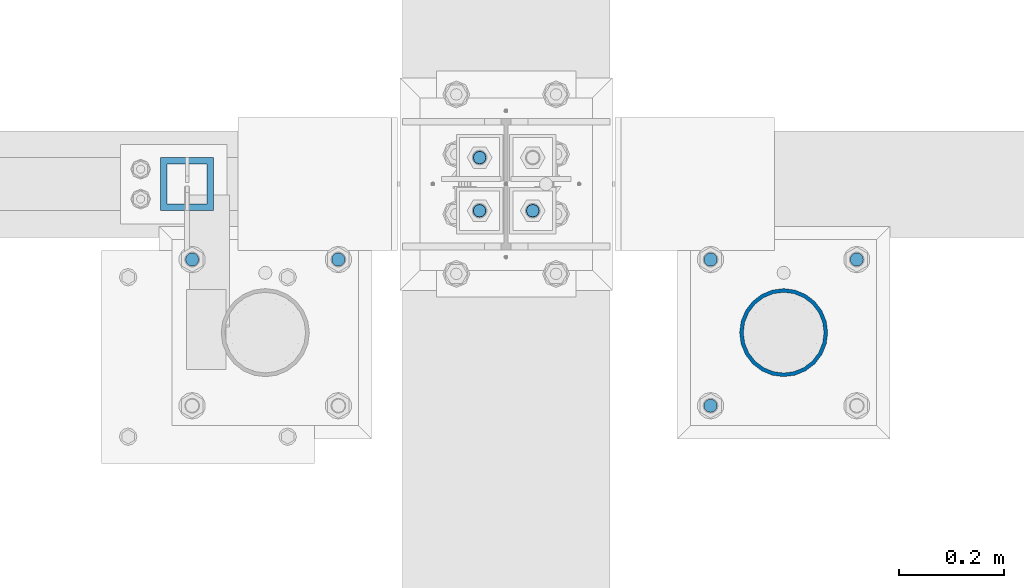
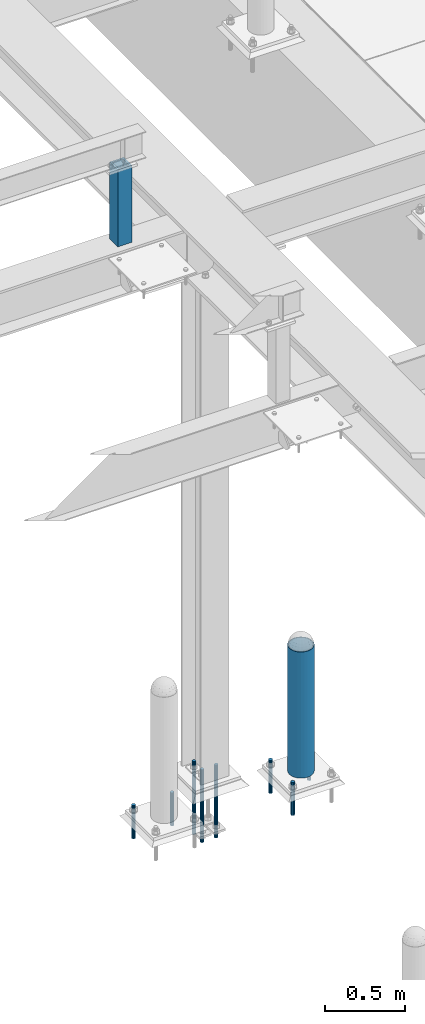
# One storey, part 1445 of 3843: 10 columns, 5 elements without a shape of their own.
"""IFC2X3 building model written with IfcOpenShell, lengths in millimetres."""

from ifc_helpers import new_model, si_unit, frame, origin_with_axes, place, context, subcontext, project, spatial, faceted_brep, material, type_object, element, aggregate, save


model = new_model("IFC2X3")

# Units and contexts
model_context = context("Model", 3, precision=1e-05, world=origin_with_axes())
body_context = subcontext(model_context, "Body", "Model", "MODEL_VIEW")
ifc_project = project(units=[si_unit("LENGTHUNIT", "METRE", prefix="MILLI"), si_unit("AREAUNIT", "SQUARE_METRE"), si_unit("VOLUMEUNIT", "CUBIC_METRE"), si_unit("MASSUNIT", "GRAM", prefix="KILO"), si_unit("TIMEUNIT", "SECOND"), si_unit("PLANEANGLEUNIT", "RADIAN"), si_unit("SOLIDANGLEUNIT", "STERADIAN"), si_unit("THERMODYNAMICTEMPERATUREUNIT", "DEGREE_CELSIUS"), si_unit("LUMINOUSINTENSITYUNIT", "LUMEN")], contexts=[model_context])

# Site, building, storey
site_placement = place(None, origin_with_axes())
site = spatial("IfcSite", under=ifc_project, at=site_placement, CompositionType="ELEMENT")
building_placement = place(site_placement, origin_with_axes())
building = spatial("IfcBuilding", under=site, at=building_placement, Name="Undefined", CompositionType="ELEMENT")
storey_placement = place(building_placement, origin_with_axes())
storey = spatial("IfcBuildingStorey", under=building, at=storey_placement, Name="Undefined", CompositionType="ELEMENT", Elevation=0.0)

# Assembly, column
assembly_1_placement = place(storey_placement, origin_with_axes())
assembly_1 = element("IfcElementAssembly", 1, at=assembly_1_placement, inside=storey, Name="PIPE_BOLLARD", AssemblyPlace="NOTDEFINED", PredefinedType="RIGID_FRAME")
ifc_material_1 = material()
column_type_1 = type_object("IfcColumnType", Name="PIPE6SCH40", PredefinedType="NOTDEFINED")
column_1_placement = place(assembly_1_placement, frame((37106.2721557617, 14714.9457781578, 30480.0), z_axis=(-1.0, 0.0, 0.0), x_axis=(0.0, 0.0, 1.0)))
column_1 = element("IfcColumn", 2, at=column_1_placement, type_object=column_type_1, material=ifc_material_1, Name="PIPE_BOLLARD", ObjectType="PIPE6SCH40", context=body_context, shape_type="Brep", body=[
    faceted_brep([(50.7999999999993, -77.0890000000072, 0.0), (50.7999999999993, -74.4622560228017, 19.9521013679114), (1016.0, -74.4622560228017, 19.9521013679114), (1016.0, -77.0890000000072, 0.0), (50.7999999999993, -66.7610323523404, 38.5445000000036), (1016.0, -66.7610323523404, 38.5445000000036), (50.7999999999993, -54.5101546548831, 54.5101546548904), (1016.0, -54.5101546548831, 54.5101546548904), (50.7999999999993, -38.5445000000036, 66.7610323523404), (1016.0, -38.5445000000036, 66.7610323523404), (50.7999999999993, -19.9521013679041, 74.4622560227945), (1016.0, -19.9521013679041, 74.4622560227945), (50.7999999999993, 0.0, 77.0889999999999), (1016.0, 0.0, 77.0889999999999), (50.7999999999993, 19.9521013679041, 74.4622560227945), (1016.0, 19.9521013679041, 74.4622560227945), (50.7999999999993, 38.5445000000036, 66.7610323523404), (1016.0, 38.5445000000036, 66.7610323523404), (50.7999999999993, 54.5101546548831, 54.5101546548904), (1016.0, 54.5101546548831, 54.5101546548904), (50.7999999999993, 66.7610323523404, 38.5445000000036), (1016.0, 66.7610323523404, 38.5445000000036), (50.7999999999993, 74.4622560228017, 19.9521013679114), (1016.0, 74.4622560228017, 19.9521013679114), (50.7999999999993, 77.0890000000072, 0.0), (1016.0, 77.0890000000072, 0.0), (50.7999999999993, 74.4622560228017, -19.9521013679114), (1016.0, 74.4622560228017, -19.9521013679114), (50.7999999999993, 66.7610323523404, -38.5445000000036), (1016.0, 66.7610323523404, -38.5445000000036), (50.7999999999993, 54.5101546548831, -54.5101546548904), (1016.0, 54.5101546548831, -54.5101546548904), (50.7999999999993, 38.5445000000036, -66.7610323523404), (1016.0, 38.5445000000036, -66.7610323523404), (50.7999999999993, 19.9521013679041, -74.4622560227945), (1016.0, 19.9521013679041, -74.4622560227945), (50.7999999999993, 0.0, -77.0889999999999), (1016.0, 0.0, -77.0889999999999), (50.7999999999993, -19.9521013679041, -74.4622560227945), (1016.0, -19.9521013679041, -74.4622560227945), (50.7999999999993, -38.5445000000036, -66.7610323523404), (1016.0, -38.5445000000036, -66.7610323523404), (50.7999999999993, -54.5101546548831, -54.5101546548904), (1016.0, -54.5101546548831, -54.5101546548904), (50.7999999999993, -66.7610323523404, -38.5445000000036), (1016.0, -66.7610323523404, -38.5445000000036), (50.7999999999993, -74.4622560228017, -19.9521013679114), (1016.0, -74.4622560228017, -19.9521013679114), (50.7999999999993, -84.2010000000009, 0.0), (50.7999999999993, -81.3319204993604, -21.7928224166753), (1016.0, -81.3319204993604, -21.7928224166753), (1016.0, -84.2010000000009, 0.0), (50.7999999999993, -72.9202050240565, -42.1005000000005), (1016.0, -72.9202050240565, -42.1005000000005), (50.7999999999993, -59.5390980826924, -59.5390980826851), (1016.0, -59.5390980826924, -59.5390980826851), (50.7999999999993, -42.1005000000005, -72.9202050240565), (1016.0, -42.1005000000005, -72.9202050240565), (50.7999999999993, -21.7928224166826, -81.3319204993677), (1016.0, -21.7928224166826, -81.3319204993677), (50.7999999999993, 0.0, -84.2010000000009), (1016.0, 0.0, -84.2010000000009), (50.7999999999993, 21.7928224166826, -81.3319204993677), (1016.0, 21.7928224166826, -81.3319204993677), (50.7999999999993, 42.1005000000005, -72.9202050240565), (1016.0, 42.1005000000005, -72.9202050240565), (50.7999999999993, 59.5390980826924, -59.5390980826851), (1016.0, 59.5390980826924, -59.5390980826851), (50.7999999999993, 72.9202050240565, -42.1005000000005), (1016.0, 72.9202050240565, -42.1005000000005), (50.7999999999993, 81.3319204993604, -21.7928224166753), (1016.0, 81.3319204993604, -21.7928224166753), (50.7999999999993, 84.2010000000009, 0.0), (1016.0, 84.2010000000009, 0.0), (50.7999999999993, 81.3319204993604, 21.7928224166753), (1016.0, 81.3319204993604, 21.7928224166753), (50.7999999999993, 72.9202050240565, 42.1005000000005), (1016.0, 72.9202050240565, 42.1005000000005), (50.7999999999993, 59.5390980826924, 59.5390980826851), (1016.0, 59.5390980826924, 59.5390980826851), (50.7999999999993, 42.1005000000005, 72.9202050240565), (1016.0, 42.1005000000005, 72.9202050240565), (50.7999999999993, 21.7928224166826, 81.3319204993677), (1016.0, 21.7928224166826, 81.3319204993677), (50.7999999999993, 0.0, 84.2010000000009), (1016.0, 0.0, 84.2010000000009), (50.7999999999993, -21.7928224166826, 81.3319204993677), (1016.0, -21.7928224166826, 81.3319204993677), (50.7999999999993, -42.1005000000005, 72.9202050240565), (1016.0, -42.1005000000005, 72.9202050240565), (50.7999999999993, -59.5390980826924, 59.5390980826851), (1016.0, -59.5390980826924, 59.5390980826851), (50.7999999999993, -72.9202050240565, 42.1005000000005), (1016.0, -72.9202050240565, 42.1005000000005), (50.7999999999993, -81.3319204993604, 21.7928224166753), (1016.0, -81.3319204993604, 21.7928224166753)], [[[0, 1, 2, 3]], [[1, 4, 5, 2]], [[4, 6, 7, 5]], [[6, 8, 9, 7]], [[8, 10, 11, 9]], [[10, 12, 13, 11]], [[12, 14, 15, 13]], [[14, 16, 17, 15]], [[16, 18, 19, 17]], [[18, 20, 21, 19]], [[20, 22, 23, 21]], [[22, 24, 25, 23]], [[24, 26, 27, 25]], [[26, 28, 29, 27]], [[28, 30, 31, 29]], [[30, 32, 33, 31]], [[32, 34, 35, 33]], [[34, 36, 37, 35]], [[36, 38, 39, 37]], [[38, 40, 41, 39]], [[40, 42, 43, 41]], [[42, 44, 45, 43]], [[44, 46, 47, 45]], [[46, 0, 3, 47]], [[48, 49, 50, 51]], [[49, 52, 53, 50]], [[52, 54, 55, 53]], [[54, 56, 57, 55]], [[56, 58, 59, 57]], [[58, 60, 61, 59]], [[60, 62, 63, 61]], [[62, 64, 65, 63]], [[64, 66, 67, 65]], [[66, 68, 69, 67]], [[68, 70, 71, 69]], [[70, 72, 73, 71]], [[72, 74, 75, 73]], [[74, 76, 77, 75]], [[76, 78, 79, 77]], [[78, 80, 81, 79]], [[80, 82, 83, 81]], [[82, 84, 85, 83]], [[84, 86, 87, 85]], [[86, 88, 89, 87]], [[88, 90, 91, 89]], [[90, 92, 93, 91]], [[92, 94, 95, 93]], [[94, 48, 51, 95]], [[53, 55, 57, 59, 61, 63, 65, 67, 69, 71, 73, 75, 77, 79, 81, 83, 85, 87, 89, 91, 93, 95, 51, 50], [5, 7, 9, 11, 13, 15, 17, 19, 21, 23, 25, 27, 29, 31, 33, 35, 37, 39, 41, 43, 45, 47, 3, 2]], [[94, 92, 90, 88, 86, 84, 82, 80, 78, 76, 74, 72, 70, 68, 66, 64, 62, 60, 58, 56, 54, 52, 49, 48], [46, 44, 42, 40, 38, 36, 34, 32, 30, 28, 26, 24, 22, 20, 18, 16, 14, 12, 10, 8, 6, 4, 1, 0]]]),
])
aggregate(assembly_1, [column_1])

# Assembly, columns
assembly_2_placement = place(storey_placement, origin_with_axes())
assembly_2 = element("IfcElementAssembly", 3, at=assembly_2_placement, inside=storey, Name="TEMPLATE", AssemblyPlace="NOTDEFINED", PredefinedType="RIGID_FRAME")
ifc_material_2 = material(Name="STEEL/316 SS")
column_type_2 = type_object("IfcColumnType", PredefinedType="NOTDEFINED")
column_2_placement = place(assembly_2_placement, frame((36255.3715698242, 14854.6457781578, 30581.6), z_axis=(-1.0, 0.0, 0.0), x_axis=(0.0, 0.0, -1.0)))
column_2 = element("IfcColumn", 4, at=column_2_placement, type_object=column_type_2, material=ifc_material_2, Name="ANCHOR_ROD", context=body_context, shape_type="Brep", body=[
    faceted_brep([(0.0, -12.6999999999971, 0.0), (0.0, -10.9985226280696, -6.34999999999854), (253.999, -10.9985226280696, -6.34999999999854), (253.999, -12.6999999999971, 0.0), (0.0, -6.35000000000582, -10.9985226280623), (253.999, -6.35000000000582, -10.9985226280623), (0.0, 0.0, -12.6999999999971), (253.999, 0.0, -12.6999999999971), (0.0, 6.35000000000582, -10.9985226280623), (253.999, 6.35000000000582, -10.9985226280623), (0.0, 10.9985226280696, -6.34999999999854), (253.999, 10.9985226280696, -6.34999999999854), (0.0, 12.6999999999971, 0.0), (253.999, 12.6999999999971, 0.0), (0.0, 10.9985226280696, 6.34999999999854), (253.999, 10.9985226280696, 6.34999999999854), (0.0, 6.35000000000582, 10.9985226280623), (253.999, 6.35000000000582, 10.9985226280623), (0.0, 0.0, 12.6999999999971), (253.999, 0.0, 12.6999999999971), (0.0, -6.35000000000582, 10.9985226280623), (253.999, -6.35000000000582, 10.9985226280623), (0.0, -10.9985226280696, 6.34999999999854), (253.999, -10.9985226280696, 6.34999999999854)], [[[0, 1, 2, 3]], [[1, 4, 5, 2]], [[4, 6, 7, 5]], [[6, 8, 9, 7]], [[8, 10, 11, 9]], [[10, 12, 13, 11]], [[12, 14, 15, 13]], [[14, 16, 17, 15]], [[16, 18, 19, 17]], [[18, 20, 21, 19]], [[20, 22, 23, 21]], [[22, 0, 3, 23]], [[5, 7, 9, 11, 13, 15, 17, 19, 21, 23, 3, 2]], [[22, 20, 18, 16, 14, 12, 10, 8, 6, 4, 1, 0]]]),
])
column_3_placement = place(assembly_2_placement, frame((35975.9715698242, 14854.6457781578, 30581.6), z_axis=(-1.0, 0.0, 0.0), x_axis=(0.0, 0.0, -1.0)))
column_3 = element("IfcColumn", 5, at=column_3_placement, type_object=column_type_2, material=ifc_material_2, Name="ANCHOR_ROD", context=body_context, shape_type="Brep", body=[
    faceted_brep([(0.0, -12.6999999999971, 0.0), (0.0, -10.9985226280696, -6.34999999999854), (253.999, -10.9985226280696, -6.34999999999854), (253.999, -12.6999999999971, 0.0), (0.0, -6.35000000000582, -10.9985226280623), (253.999, -6.35000000000582, -10.9985226280623), (0.0, 0.0, -12.6999999999971), (253.999, 0.0, -12.6999999999971), (0.0, 6.35000000000582, -10.9985226280623), (253.999, 6.35000000000582, -10.9985226280623), (0.0, 10.9985226280696, -6.34999999999854), (253.999, 10.9985226280696, -6.34999999999854), (0.0, 12.6999999999971, 0.0), (253.999, 12.6999999999971, 0.0), (0.0, 10.9985226280696, 6.34999999999854), (253.999, 10.9985226280696, 6.34999999999854), (0.0, 6.35000000000582, 10.9985226280623), (253.999, 6.35000000000582, 10.9985226280623), (0.0, 0.0, 12.6999999999971), (253.999, 0.0, 12.6999999999971), (0.0, -6.35000000000582, 10.9985226280623), (253.999, -6.35000000000582, 10.9985226280623), (0.0, -10.9985226280696, 6.34999999999854), (253.999, -10.9985226280696, 6.34999999999854)], [[[0, 1, 2, 3]], [[1, 4, 5, 2]], [[4, 6, 7, 5]], [[6, 8, 9, 7]], [[8, 10, 11, 9]], [[10, 12, 13, 11]], [[12, 14, 15, 13]], [[14, 16, 17, 15]], [[16, 18, 19, 17]], [[18, 20, 21, 19]], [[20, 22, 23, 21]], [[22, 0, 3, 23]], [[5, 7, 9, 11, 13, 15, 17, 19, 21, 23, 3, 2]], [[22, 20, 18, 16, 14, 12, 10, 8, 6, 4, 1, 0]]]),
])
aggregate(assembly_2, [column_2, column_3])

assembly_3_placement = place(storey_placement, origin_with_axes())
assembly_3 = element("IfcElementAssembly", 6, at=assembly_3_placement, inside=storey, Name="TEMPLATE", AssemblyPlace="NOTDEFINED", PredefinedType="RIGID_FRAME")
column_4_placement = place(assembly_3_placement, frame((37245.9721557617, 14854.6457781578, 30581.6), z_axis=(-1.0, 0.0, 0.0), x_axis=(0.0, 0.0, -1.0)))
column_4 = element("IfcColumn", 7, at=column_4_placement, type_object=column_type_2, material=ifc_material_2, Name="ANCHOR_ROD", context=body_context, shape_type="Brep", body=[
    faceted_brep([(0.0, -12.6999999999971, 0.0), (0.0, -10.9985226280696, -6.34999999999854), (253.999, -10.9985226280696, -6.34999999999854), (253.999, -12.6999999999971, 0.0), (0.0, -6.35000000000582, -10.9985226280623), (253.999, -6.35000000000582, -10.9985226280623), (0.0, 0.0, -12.6999999999971), (253.999, 0.0, -12.6999999999971), (0.0, 6.35000000000582, -10.9985226280623), (253.999, 6.35000000000582, -10.9985226280623), (0.0, 10.9985226280696, -6.34999999999854), (253.999, 10.9985226280696, -6.34999999999854), (0.0, 12.6999999999971, 0.0), (253.999, 12.6999999999971, 0.0), (0.0, 10.9985226280696, 6.34999999999854), (253.999, 10.9985226280696, 6.34999999999854), (0.0, 6.35000000000582, 10.9985226280623), (253.999, 6.35000000000582, 10.9985226280623), (0.0, 0.0, 12.6999999999971), (253.999, 0.0, 12.6999999999971), (0.0, -6.35000000000582, 10.9985226280623), (253.999, -6.35000000000582, 10.9985226280623), (0.0, -10.9985226280696, 6.34999999999854), (253.999, -10.9985226280696, 6.34999999999854)], [[[0, 1, 2, 3]], [[1, 4, 5, 2]], [[4, 6, 7, 5]], [[6, 8, 9, 7]], [[8, 10, 11, 9]], [[10, 12, 13, 11]], [[12, 14, 15, 13]], [[14, 16, 17, 15]], [[16, 18, 19, 17]], [[18, 20, 21, 19]], [[20, 22, 23, 21]], [[22, 0, 3, 23]], [[5, 7, 9, 11, 13, 15, 17, 19, 21, 23, 3, 2]], [[22, 20, 18, 16, 14, 12, 10, 8, 6, 4, 1, 0]]]),
])
column_5_placement = place(assembly_3_placement, frame((36966.5721557617, 14575.2457781578, 30581.6), z_axis=(1.0, 0.0, 0.0), x_axis=(0.0, 0.0, -1.0)))
column_5 = element("IfcColumn", 8, at=column_5_placement, type_object=column_type_2, material=ifc_material_2, Name="ANCHOR_ROD", context=body_context, shape_type="Brep", body=[
    faceted_brep([(0.0, -12.6999999999971, 0.0), (0.0, -10.9985226280696, -6.34999999999854), (253.999, -10.9985226280696, -6.34999999999854), (253.999, -12.6999999999971, 0.0), (0.0, -6.35000000000582, -10.9985226280623), (253.999, -6.35000000000582, -10.9985226280623), (0.0, 0.0, -12.6999999999971), (253.999, 0.0, -12.6999999999971), (0.0, 6.35000000000582, -10.9985226280623), (253.999, 6.35000000000582, -10.9985226280623), (0.0, 10.9985226280696, -6.34999999999854), (253.999, 10.9985226280696, -6.34999999999854), (0.0, 12.6999999999971, 0.0), (253.999, 12.6999999999971, 0.0), (0.0, 10.9985226280696, 6.34999999999854), (253.999, 10.9985226280696, 6.34999999999854), (0.0, 6.35000000000582, 10.9985226280623), (253.999, 6.35000000000582, 10.9985226280623), (0.0, 0.0, 12.6999999999971), (253.999, 0.0, 12.6999999999971), (0.0, -6.35000000000582, 10.9985226280623), (253.999, -6.35000000000582, 10.9985226280623), (0.0, -10.9985226280696, 6.34999999999854), (253.999, -10.9985226280696, 6.34999999999854)], [[[0, 1, 2, 3]], [[1, 4, 5, 2]], [[4, 6, 7, 5]], [[6, 8, 9, 7]], [[8, 10, 11, 9]], [[10, 12, 13, 11]], [[12, 14, 15, 13]], [[14, 16, 17, 15]], [[16, 18, 19, 17]], [[18, 20, 21, 19]], [[20, 22, 23, 21]], [[22, 0, 3, 23]], [[5, 7, 9, 11, 13, 15, 17, 19, 21, 23, 3, 2]], [[22, 20, 18, 16, 14, 12, 10, 8, 6, 4, 1, 0]]]),
])
column_6_placement = place(assembly_3_placement, frame((36966.5721557617, 14854.6457781578, 30581.6), z_axis=(-1.0, 0.0, 0.0), x_axis=(0.0, 0.0, -1.0)))
column_6 = element("IfcColumn", 9, at=column_6_placement, type_object=column_type_2, material=ifc_material_2, Name="ANCHOR_ROD", context=body_context, shape_type="Brep", body=[
    faceted_brep([(0.0, -12.6999999999971, 0.0), (0.0, -10.9985226280696, -6.34999999999854), (253.999, -10.9985226280696, -6.34999999999854), (253.999, -12.6999999999971, 0.0), (0.0, -6.35000000000582, -10.9985226280623), (253.999, -6.35000000000582, -10.9985226280623), (0.0, 0.0, -12.6999999999971), (253.999, 0.0, -12.6999999999971), (0.0, 6.35000000000582, -10.9985226280623), (253.999, 6.35000000000582, -10.9985226280623), (0.0, 10.9985226280696, -6.34999999999854), (253.999, 10.9985226280696, -6.34999999999854), (0.0, 12.6999999999971, 0.0), (253.999, 12.6999999999971, 0.0), (0.0, 10.9985226280696, 6.34999999999854), (253.999, 10.9985226280696, 6.34999999999854), (0.0, 6.35000000000582, 10.9985226280623), (253.999, 6.35000000000582, 10.9985226280623), (0.0, 0.0, 12.6999999999971), (253.999, 0.0, 12.6999999999971), (0.0, -6.35000000000582, 10.9985226280623), (253.999, -6.35000000000582, 10.9985226280623), (0.0, -10.9985226280696, 6.34999999999854), (253.999, -10.9985226280696, 6.34999999999854)], [[[0, 1, 2, 3]], [[1, 4, 5, 2]], [[4, 6, 7, 5]], [[6, 8, 9, 7]], [[8, 10, 11, 9]], [[10, 12, 13, 11]], [[12, 14, 15, 13]], [[14, 16, 17, 15]], [[16, 18, 19, 17]], [[18, 20, 21, 19]], [[20, 22, 23, 21]], [[22, 0, 3, 23]], [[5, 7, 9, 11, 13, 15, 17, 19, 21, 23, 3, 2]], [[22, 20, 18, 16, 14, 12, 10, 8, 6, 4, 1, 0]]]),
])
aggregate(assembly_3, [column_4, column_5, column_6])

# Assembly, column
assembly_4_placement = place(storey_placement, origin_with_axes())
assembly_4 = element("IfcElementAssembly", 10, at=assembly_4_placement, inside=storey, Name="POST", AssemblyPlace="NOTDEFINED", PredefinedType="RIGID_FRAME")
ifc_material_3 = material()
column_type_3 = type_object("IfcColumnType", Name="HSS4X4X1/2", PredefinedType="NOTDEFINED")
column_7_placement = place(assembly_4_placement, frame((35966.4, 14998.7, 34810.7), z_axis=(0.0, 1.0, 0.0), x_axis=(0.0, 0.0, 1.0)))
column_7 = element("IfcColumn", 11, at=column_7_placement, type_object=column_type_3, material=ifc_material_3, Name="POST", ObjectType="HSS4X4X1/2", context=body_context, shape_type="Brep", body=[
    faceted_brep([(0.0, 38.0999999999985, -38.0999999999985), (0.0, -38.0999999999985, -38.0999999999985), (590.549996948241, -38.0999999999985, -38.1000000000004), (590.549996948241, 38.0999999999985, -38.1000000000004), (0.0, -38.0999999999985, 38.1000000000004), (590.549996948241, -38.0999999999985, 38.1000000000004), (0.0, 38.0999999999985, 38.0999999999985), (590.549996948241, 38.0999999999985, 38.1000000000004), (0.0, 50.8000000000029, -50.8000000000029), (0.0, 50.8000000000029, 50.8000000000029), (590.549996948241, 50.8000000000029, 50.7999999999993), (590.549996948241, 50.8000000000029, -50.7999999999993), (0.0, -50.8000000000029, 50.8000000000029), (590.549996948241, -50.8000000000029, 50.7999999999993), (0.0, -50.8000000000029, -50.8000000000029), (590.549996948241, -50.8000000000029, -50.7999999999993)], [[[0, 1, 2, 3]], [[1, 4, 5, 2]], [[4, 6, 7, 5]], [[6, 0, 3, 7]], [[8, 9, 10, 11]], [[9, 12, 13, 10]], [[12, 14, 15, 13]], [[14, 8, 11, 15]], [[13, 15, 11, 10], [5, 7, 3, 2]], [[14, 12, 9, 8], [6, 4, 1, 0]]]),
])
aggregate(assembly_4, [column_7])

# Assembly, columns
assembly_5_placement = place(storey_placement, origin_with_axes())
assembly_5 = element("IfcElementAssembly", 12, at=assembly_5_placement, inside=storey, Name="TEMPLATE", AssemblyPlace="NOTDEFINED", PredefinedType="RIGID_FRAME")
ifc_material_4 = material(Name="Undefined/F1554-GR.55")
column_type_4 = type_object("IfcColumnType", PredefinedType="NOTDEFINED")
column_8_placement = place(assembly_5_placement, frame((36525.2, 14947.9, 30480.0), z_axis=(0.0, -1.0, 0.0), x_axis=(0.0, 0.0, -1.0)))
column_8 = element("IfcColumn", 13, at=column_8_placement, type_object=column_type_4, material=ifc_material_4, Name="ANCHOR_ROD", context=body_context, shape_type="Brep", body=[
    faceted_brep([(-127.0, -10.3923048454162, 6.0), (-127.0, -6.0, 10.3923048454126), (-127.0, 0.0, 12.0), (-127.0, 6.0, 10.3923048454126), (-127.0, 10.3923048454162, 6.0), (-127.0, 12.0, 0.0), (-127.0, 10.3923048454162, -6.0), (-127.0, 6.0, -10.3923048454126), (-127.0, 0.0, -12.0), (-127.0, -6.0, -10.3923048454126), (-127.0, -10.3923048454162, -6.0), (-127.0, -12.0, 0.0), (0.0, 12.0, 0.0), (0.0, 10.3923048454162, -6.0), (0.0, 6.0, -10.3923048454126), (0.0, 0.0, -12.0), (0.0, -6.0, -10.3923048454126), (0.0, -10.3923048454162, -6.0), (0.0, -12.0, 0.0), (0.0, -10.3923048454162, 6.0), (0.0, -6.0, 10.3923048454126), (0.0, 0.0, 12.0), (0.0, 6.0, 10.3923048454126), (0.0, 10.3923048454162, 6.0), (0.0, -10.9985226280696, 6.34999999999854), (0.0, -6.35000000000582, 10.9985226280623), (0.0, 0.0, 12.6999999999971), (0.0, 6.35000000000582, 10.9985226280623), (0.0, 10.9985226280696, 6.34999999999854), (0.0, 12.6999999999971, 0.0), (0.0, 10.9985226280696, -6.34999999999854), (0.0, 6.35000000000582, -10.9985226280623), (0.0, 0.0, -12.6999999999971), (0.0, -6.35000000000582, -10.9985226280623), (0.0, -10.9985226280696, -6.34999999999854), (0.0, -12.6999999999971, 0.0), (304.799999999999, -12.6999999999971, 0.0), (304.799999999999, -10.9985226280623, 6.35000000000036), (304.799999999999, -6.34999999999854, 10.9985226280623), (304.799999999999, 0.0, 12.7000000000007), (304.799999999999, 6.34999999999854, 10.9985226280623), (304.799999999999, 10.9985226280623, 6.35000000000036), (304.799999999999, 12.6999999999971, 0.0), (304.799999999999, 10.9985226280623, -6.35000000000036), (304.799999999999, 6.34999999999854, -10.9985226280623), (304.799999999999, 0.0, -12.7000000000007), (304.799999999999, -6.34999999999854, -10.9985226280623), (304.799999999999, -10.9985226280623, -6.35000000000036), (304.799999999999, -6.0, 10.3923048454126), (304.799999999999, 0.0, 12.0), (304.799999999999, 6.0, 10.3923048454126), (304.799999999999, 10.3923048454162, 6.0), (304.799999999999, 12.0, 0.0), (304.799999999999, 10.3923048454162, -6.0), (304.799999999999, 6.0, -10.3923048454126), (304.799999999999, 0.0, -12.0), (304.799999999999, -6.0, -10.3923048454126), (304.799999999999, -10.3923048454162, -6.0), (304.799999999999, -12.0, 0.0), (304.799999999999, -10.3923048454162, 6.0), (431.799999999999, -6.0, -10.3923048454126), (431.799999999999, 0.0, -12.0), (431.799999999999, 6.0, -10.3923048454126), (431.799999999999, 10.3923048454162, -6.0), (431.799999999999, 12.0, 0.0), (431.799999999999, 10.3923048454162, 6.0), (431.799999999999, 6.0, 10.3923048454126), (431.799999999999, 0.0, 12.0), (431.799999999999, -6.0, 10.3923048454126), (431.799999999999, -10.3923048454162, 6.0), (431.799999999999, -12.0, 0.0), (431.799999999999, -10.3923048454162, -6.0)], [[[0, 1, 2, 3, 4, 5, 6, 7, 8, 9, 10, 11]], [[6, 5, 12, 13]], [[7, 6, 13, 14]], [[8, 7, 14, 15]], [[9, 8, 15, 16]], [[10, 9, 16, 17]], [[11, 10, 17, 18]], [[0, 11, 18, 19]], [[1, 0, 19, 20]], [[2, 1, 20, 21]], [[3, 2, 21, 22]], [[4, 3, 22, 23]], [[5, 4, 23, 12]], [[24, 25, 26, 27, 28, 29, 30, 31, 32, 33, 34, 35], [22, 21, 20, 19, 18, 17, 16, 15, 14, 13, 12, 23]], [[24, 35, 36, 37]], [[25, 24, 37, 38]], [[26, 25, 38, 39]], [[27, 26, 39, 40]], [[28, 27, 40, 41]], [[29, 28, 41, 42]], [[30, 29, 42, 43]], [[31, 30, 43, 44]], [[32, 31, 44, 45]], [[33, 32, 45, 46]], [[34, 33, 46, 47]], [[35, 34, 47, 36]], [[46, 45, 44, 43, 42, 41, 40, 39, 38, 37, 36, 47], [48, 49, 50, 51, 52, 53, 54, 55, 56, 57, 58, 59]], [[60, 61, 62, 63, 64, 65, 66, 67, 68, 69, 70, 71]], [[68, 67, 49, 48]], [[69, 68, 48, 59]], [[70, 69, 59, 58]], [[71, 70, 58, 57]], [[60, 71, 57, 56]], [[61, 60, 56, 55]], [[62, 61, 55, 54]], [[63, 62, 54, 53]], [[64, 63, 53, 52]], [[65, 64, 52, 51]], [[66, 65, 51, 50]], [[67, 66, 50, 49]]]),
])
column_9_placement = place(assembly_5_placement, frame((36626.8, 14947.9, 30480.0), z_axis=(0.0, 1.0, 0.0), x_axis=(0.0, 0.0, -1.0)))
column_9 = element("IfcColumn", 14, at=column_9_placement, type_object=column_type_4, material=ifc_material_4, Name="ANCHOR_ROD", context=body_context, shape_type="Brep", body=[
    faceted_brep([(-127.0, -10.3923048454162, 6.0), (-127.0, -6.0, 10.3923048454126), (-127.0, 0.0, 12.0), (-127.0, 6.0, 10.3923048454126), (-127.0, 10.3923048454162, 6.0), (-127.0, 12.0, 0.0), (-127.0, 10.3923048454162, -6.0), (-127.0, 6.0, -10.3923048454126), (-127.0, 0.0, -12.0), (-127.0, -6.0, -10.3923048454126), (-127.0, -10.3923048454162, -6.0), (-127.0, -12.0, 0.0), (0.0, 12.0, 0.0), (0.0, 10.3923048454162, -6.0), (0.0, 6.0, -10.3923048454126), (0.0, 0.0, -12.0), (0.0, -6.0, -10.3923048454126), (0.0, -10.3923048454162, -6.0), (0.0, -12.0, 0.0), (0.0, -10.3923048454162, 6.0), (0.0, -6.0, 10.3923048454126), (0.0, 0.0, 12.0), (0.0, 6.0, 10.3923048454126), (0.0, 10.3923048454162, 6.0), (0.0, -10.9985226280696, 6.34999999999854), (0.0, -6.35000000000582, 10.9985226280623), (0.0, 0.0, 12.6999999999971), (0.0, 6.35000000000582, 10.9985226280623), (0.0, 10.9985226280696, 6.34999999999854), (0.0, 12.6999999999971, 0.0), (0.0, 10.9985226280696, -6.34999999999854), (0.0, 6.35000000000582, -10.9985226280623), (0.0, 0.0, -12.6999999999971), (0.0, -6.35000000000582, -10.9985226280623), (0.0, -10.9985226280696, -6.34999999999854), (0.0, -12.6999999999971, 0.0), (304.799999999999, -12.6999999999971, 0.0), (304.799999999999, -10.9985226280623, 6.35000000000036), (304.799999999999, -6.34999999999854, 10.9985226280623), (304.799999999999, 0.0, 12.7000000000007), (304.799999999999, 6.34999999999854, 10.9985226280623), (304.799999999999, 10.9985226280623, 6.35000000000036), (304.799999999999, 12.6999999999971, 0.0), (304.799999999999, 10.9985226280623, -6.35000000000036), (304.799999999999, 6.34999999999854, -10.9985226280623), (304.799999999999, 0.0, -12.7000000000007), (304.799999999999, -6.34999999999854, -10.9985226280623), (304.799999999999, -10.9985226280623, -6.35000000000036), (304.799999999999, -6.0, 10.3923048454126), (304.799999999999, 0.0, 12.0), (304.799999999999, 6.0, 10.3923048454126), (304.799999999999, 10.3923048454162, 6.0), (304.799999999999, 12.0, 0.0), (304.799999999999, 10.3923048454162, -6.0), (304.799999999999, 6.0, -10.3923048454126), (304.799999999999, 0.0, -12.0), (304.799999999999, -6.0, -10.3923048454126), (304.799999999999, -10.3923048454162, -6.0), (304.799999999999, -12.0, 0.0), (304.799999999999, -10.3923048454162, 6.0), (431.799999999999, -6.0, -10.3923048454126), (431.799999999999, 0.0, -12.0), (431.799999999999, 6.0, -10.3923048454126), (431.799999999999, 10.3923048454162, -6.0), (431.799999999999, 12.0, 0.0), (431.799999999999, 10.3923048454162, 6.0), (431.799999999999, 6.0, 10.3923048454126), (431.799999999999, 0.0, 12.0), (431.799999999999, -6.0, 10.3923048454126), (431.799999999999, -10.3923048454162, 6.0), (431.799999999999, -12.0, 0.0), (431.799999999999, -10.3923048454162, -6.0)], [[[0, 1, 2, 3, 4, 5, 6, 7, 8, 9, 10, 11]], [[6, 5, 12, 13]], [[7, 6, 13, 14]], [[8, 7, 14, 15]], [[9, 8, 15, 16]], [[10, 9, 16, 17]], [[11, 10, 17, 18]], [[0, 11, 18, 19]], [[1, 0, 19, 20]], [[2, 1, 20, 21]], [[3, 2, 21, 22]], [[4, 3, 22, 23]], [[5, 4, 23, 12]], [[24, 25, 26, 27, 28, 29, 30, 31, 32, 33, 34, 35], [22, 21, 20, 19, 18, 17, 16, 15, 14, 13, 12, 23]], [[24, 35, 36, 37]], [[25, 24, 37, 38]], [[26, 25, 38, 39]], [[27, 26, 39, 40]], [[28, 27, 40, 41]], [[29, 28, 41, 42]], [[30, 29, 42, 43]], [[31, 30, 43, 44]], [[32, 31, 44, 45]], [[33, 32, 45, 46]], [[34, 33, 46, 47]], [[35, 34, 47, 36]], [[46, 45, 44, 43, 42, 41, 40, 39, 38, 37, 36, 47], [48, 49, 50, 51, 52, 53, 54, 55, 56, 57, 58, 59]], [[60, 61, 62, 63, 64, 65, 66, 67, 68, 69, 70, 71]], [[68, 67, 49, 48]], [[69, 68, 48, 59]], [[70, 69, 59, 58]], [[71, 70, 58, 57]], [[60, 71, 57, 56]], [[61, 60, 56, 55]], [[62, 61, 55, 54]], [[63, 62, 54, 53]], [[64, 63, 53, 52]], [[65, 64, 52, 51]], [[66, 65, 51, 50]], [[67, 66, 50, 49]]]),
])
column_10_placement = place(assembly_5_placement, frame((36525.2, 15049.5, 30480.0), z_axis=(0.0, -1.0, 0.0), x_axis=(0.0, 0.0, -1.0)))
column_10 = element("IfcColumn", 15, at=column_10_placement, type_object=column_type_4, material=ifc_material_4, Name="ANCHOR_ROD", context=body_context, shape_type="Brep", body=[
    faceted_brep([(-127.0, -10.3923048454162, 6.0), (-127.0, -6.0, 10.3923048454126), (-127.0, 0.0, 12.0), (-127.0, 6.0, 10.3923048454126), (-127.0, 10.3923048454162, 6.0), (-127.0, 12.0, 0.0), (-127.0, 10.3923048454162, -6.0), (-127.0, 6.0, -10.3923048454126), (-127.0, 0.0, -12.0), (-127.0, -6.0, -10.3923048454126), (-127.0, -10.3923048454162, -6.0), (-127.0, -12.0, 0.0), (0.0, 12.0, 0.0), (0.0, 10.3923048454162, -6.0), (0.0, 6.0, -10.3923048454126), (0.0, 0.0, -12.0), (0.0, -6.0, -10.3923048454126), (0.0, -10.3923048454162, -6.0), (0.0, -12.0, 0.0), (0.0, -10.3923048454162, 6.0), (0.0, -6.0, 10.3923048454126), (0.0, 0.0, 12.0), (0.0, 6.0, 10.3923048454126), (0.0, 10.3923048454162, 6.0), (0.0, -10.9985226280696, 6.34999999999854), (0.0, -6.35000000000582, 10.9985226280623), (0.0, 0.0, 12.6999999999971), (0.0, 6.35000000000582, 10.9985226280623), (0.0, 10.9985226280696, 6.34999999999854), (0.0, 12.6999999999971, 0.0), (0.0, 10.9985226280696, -6.34999999999854), (0.0, 6.35000000000582, -10.9985226280623), (0.0, 0.0, -12.6999999999971), (0.0, -6.35000000000582, -10.9985226280623), (0.0, -10.9985226280696, -6.34999999999854), (0.0, -12.6999999999971, 0.0), (304.799999999999, -12.6999999999971, 0.0), (304.799999999999, -10.9985226280623, 6.35000000000036), (304.799999999999, -6.34999999999854, 10.9985226280623), (304.799999999999, 0.0, 12.7000000000007), (304.799999999999, 6.34999999999854, 10.9985226280623), (304.799999999999, 10.9985226280623, 6.35000000000036), (304.799999999999, 12.6999999999971, 0.0), (304.799999999999, 10.9985226280623, -6.35000000000036), (304.799999999999, 6.34999999999854, -10.9985226280623), (304.799999999999, 0.0, -12.7000000000007), (304.799999999999, -6.34999999999854, -10.9985226280623), (304.799999999999, -10.9985226280623, -6.35000000000036), (304.799999999999, -6.0, 10.3923048454126), (304.799999999999, 0.0, 12.0), (304.799999999999, 6.0, 10.3923048454126), (304.799999999999, 10.3923048454162, 6.0), (304.799999999999, 12.0, 0.0), (304.799999999999, 10.3923048454162, -6.0), (304.799999999999, 6.0, -10.3923048454126), (304.799999999999, 0.0, -12.0), (304.799999999999, -6.0, -10.3923048454126), (304.799999999999, -10.3923048454162, -6.0), (304.799999999999, -12.0, 0.0), (304.799999999999, -10.3923048454162, 6.0), (431.799999999999, -6.0, -10.3923048454126), (431.799999999999, 0.0, -12.0), (431.799999999999, 6.0, -10.3923048454126), (431.799999999999, 10.3923048454162, -6.0), (431.799999999999, 12.0, 0.0), (431.799999999999, 10.3923048454162, 6.0), (431.799999999999, 6.0, 10.3923048454126), (431.799999999999, 0.0, 12.0), (431.799999999999, -6.0, 10.3923048454126), (431.799999999999, -10.3923048454162, 6.0), (431.799999999999, -12.0, 0.0), (431.799999999999, -10.3923048454162, -6.0)], [[[0, 1, 2, 3, 4, 5, 6, 7, 8, 9, 10, 11]], [[6, 5, 12, 13]], [[7, 6, 13, 14]], [[8, 7, 14, 15]], [[9, 8, 15, 16]], [[10, 9, 16, 17]], [[11, 10, 17, 18]], [[0, 11, 18, 19]], [[1, 0, 19, 20]], [[2, 1, 20, 21]], [[3, 2, 21, 22]], [[4, 3, 22, 23]], [[5, 4, 23, 12]], [[24, 25, 26, 27, 28, 29, 30, 31, 32, 33, 34, 35], [22, 21, 20, 19, 18, 17, 16, 15, 14, 13, 12, 23]], [[24, 35, 36, 37]], [[25, 24, 37, 38]], [[26, 25, 38, 39]], [[27, 26, 39, 40]], [[28, 27, 40, 41]], [[29, 28, 41, 42]], [[30, 29, 42, 43]], [[31, 30, 43, 44]], [[32, 31, 44, 45]], [[33, 32, 45, 46]], [[34, 33, 46, 47]], [[35, 34, 47, 36]], [[46, 45, 44, 43, 42, 41, 40, 39, 38, 37, 36, 47], [48, 49, 50, 51, 52, 53, 54, 55, 56, 57, 58, 59]], [[60, 61, 62, 63, 64, 65, 66, 67, 68, 69, 70, 71]], [[68, 67, 49, 48]], [[69, 68, 48, 59]], [[70, 69, 59, 58]], [[71, 70, 58, 57]], [[60, 71, 57, 56]], [[61, 60, 56, 55]], [[62, 61, 55, 54]], [[63, 62, 54, 53]], [[64, 63, 53, 52]], [[65, 64, 52, 51]], [[66, 65, 51, 50]], [[67, 66, 50, 49]]]),
])
aggregate(assembly_5, [column_8, column_9, column_10])

save(model, "model.ifc")
